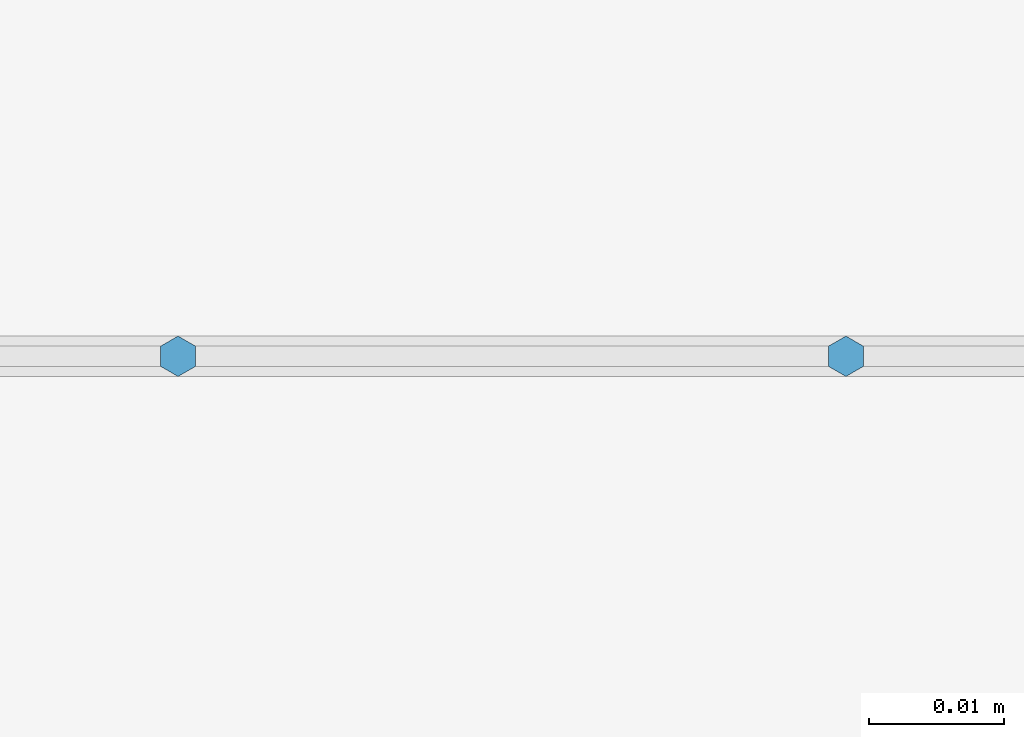
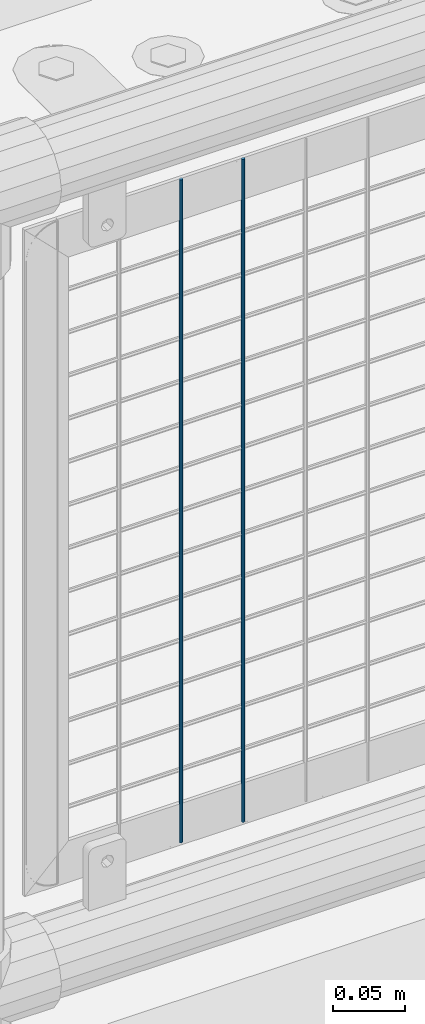
# One storey, part 80 of 208: 2 columns.
"""IFC2X3 building model written with IfcOpenShell, lengths in millimetres."""

from ifc_helpers import new_model, si_unit, frame, origin_with_axes, place, context, subcontext, project, spatial, faceted_brep, material, type_object, element, save


model = new_model("IFC2X3")

# Units and contexts
model_context = context("Model", 3, precision=1e-05, world=origin_with_axes())
body_context = subcontext(model_context, "Body", "Model", "MODEL_VIEW")
ifc_project = project(units=[si_unit("LENGTHUNIT", "METRE", prefix="MILLI"), si_unit("AREAUNIT", "SQUARE_METRE"), si_unit("VOLUMEUNIT", "CUBIC_METRE"), si_unit("MASSUNIT", "GRAM", prefix="KILO"), si_unit("TIMEUNIT", "SECOND"), si_unit("PLANEANGLEUNIT", "RADIAN"), si_unit("SOLIDANGLEUNIT", "STERADIAN"), si_unit("THERMODYNAMICTEMPERATUREUNIT", "DEGREE_CELSIUS"), si_unit("LUMINOUSINTENSITYUNIT", "LUMEN")], contexts=[model_context])

# Site, building, storey
site_placement = place(None, origin_with_axes())
site = spatial("IfcSite", under=ifc_project, at=site_placement, CompositionType="ELEMENT")
building_placement = place(site_placement, origin_with_axes())
building = spatial("IfcBuilding", under=site, at=building_placement, Name="Standard", CompositionType="ELEMENT")
storey_placement = place(building_placement, origin_with_axes())
storey = spatial("IfcBuildingStorey", under=building, at=storey_placement, Name="Undefined", CompositionType="ELEMENT", Elevation=0.0)

# Columns
ifc_material = material(Name="Misc_Undefined")
column_type = type_object("IfcColumnType", Name="D3", PredefinedType="NOTDEFINED")
for number, where, z_axis, x_axis in (
    (1, (-30400.035, 4670.50000000001, 353.020000000005), (-1.0, 0.0, 0.0), (0.0, 0.0, 1.0)),
    (2, (-30449.6896551724, 4670.50000000001, 353.020000000005), (-1.0, 0.0, 0.0), (0.0, 0.0, 1.0)),
):
    element("IfcColumn", number, at=place(storey_placement, frame(where, z_axis=z_axis, x_axis=x_axis)), inside=storey, type_object=column_type, material=ifc_material, ObjectType="D3", context=body_context, shape_type="Brep", body=[
        faceted_brep([(0.0, -1.49999999999909, 3.63797880709171e-12), (-7.27595761418343e-12, -0.749999999999091, -1.29903810567669), (560.0, -0.75, -1.29903810567703), (560.0, -1.5, 0.0), (-3.63797880709171e-12, 0.750000000000909, -1.29903810567669), (560.0, 0.75, -1.29903810567703), (0.0, 1.50000000000182, 3.63797880709171e-12), (560.0, 1.5, 0.0), (-3.63797880709171e-12, 0.750000000000909, 1.29903810567669), (560.0, 0.75, 1.29903810567703), (-7.27595761418343e-12, -0.749999999999091, 1.29903810567669), (560.0, -0.75, 1.29903810567703)], [[[0, 1, 2, 3]], [[1, 4, 5, 2]], [[4, 6, 7, 5]], [[6, 8, 9, 7]], [[8, 10, 11, 9]], [[10, 0, 3, 11]], [[5, 7, 9, 11, 3, 2]], [[10, 8, 6, 4, 1, 0]]]),
    ])

save(model, "model.ifc")
